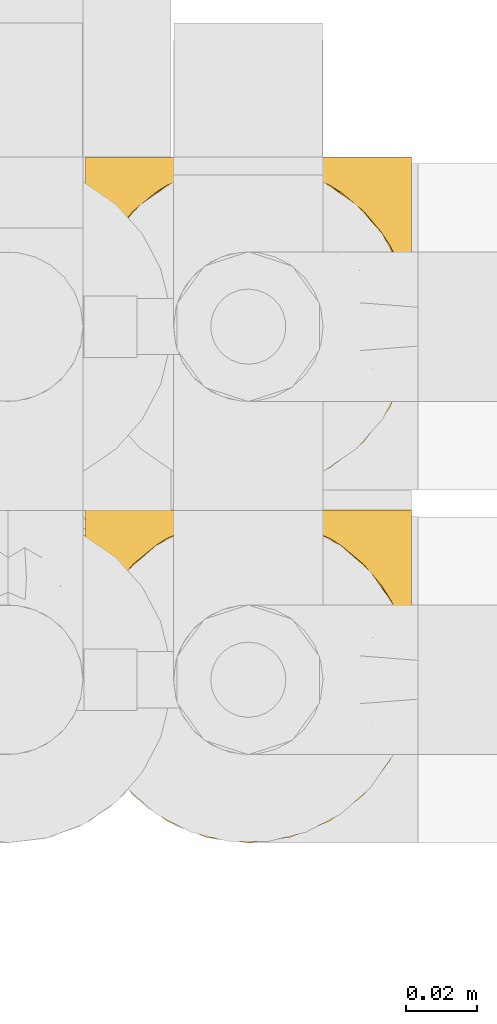
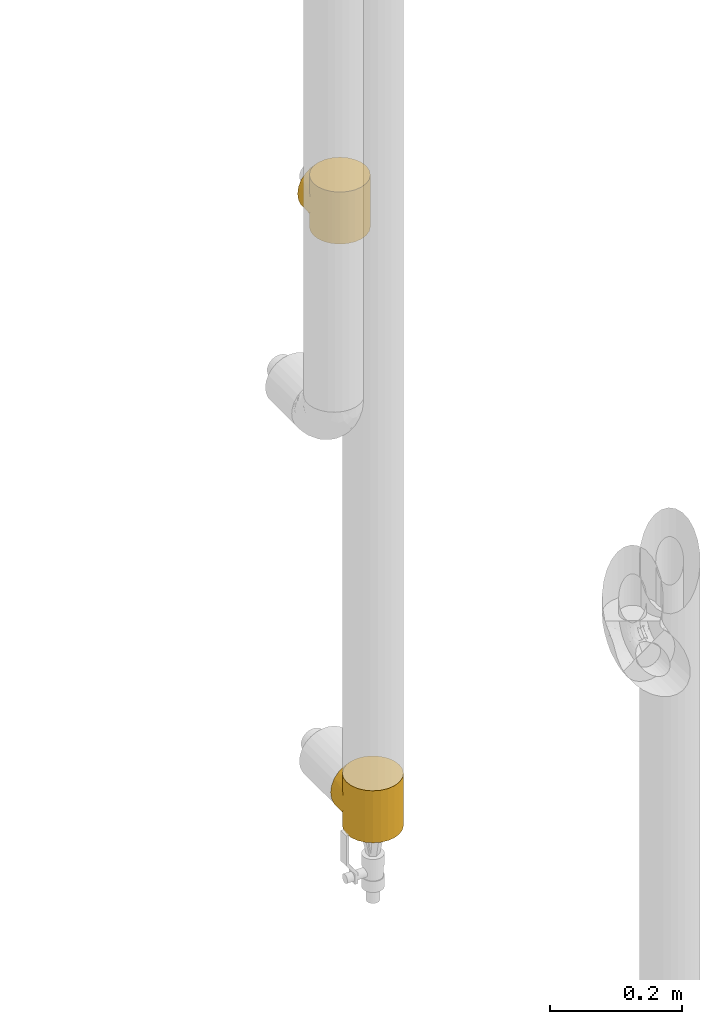
# One storey, part 252 of 827: 2 coverings.
"""IFC2X3 building model written with IfcOpenShell, lengths in millimetres."""

from ifc_helpers import new_model, entity, si_unit, converted_unit, derived_unit, direction, frame, origin, place, context, subcontext, project, spatial, faceted_brep, element, save


model = new_model("IFC2X3")

# Units and contexts
model_context = context("Model", 3, precision=0.01, world=origin(), true_north=direction((6.12303176911189e-17, 1.0)))
body_context = subcontext(model_context, "Body", "Model", "MODEL_VIEW")
ifc_project = project(units=[si_unit("LENGTHUNIT", "METRE", prefix="MILLI"), si_unit("AREAUNIT", "SQUARE_METRE"), si_unit("VOLUMEUNIT", "CUBIC_METRE"), converted_unit("PLANEANGLEUNIT", "DEGREE", entity("IfcRatioMeasure", 0.0174532925199433), si_unit("PLANEANGLEUNIT", "RADIAN"), dimensions=[0, 0, 0, 0, 0, 0, 0]), si_unit("MASSUNIT", "GRAM", prefix="KILO"), derived_unit("MASSDENSITYUNIT", [(si_unit("MASSUNIT", "GRAM", prefix="KILO"), 1), (si_unit("LENGTHUNIT", "METRE"), -3)]), derived_unit("MOMENTOFINERTIAUNIT", [(si_unit("LENGTHUNIT", "METRE"), 4)]), si_unit("TIMEUNIT", "SECOND"), si_unit("FREQUENCYUNIT", "HERTZ"), si_unit("THERMODYNAMICTEMPERATUREUNIT", "DEGREE_CELSIUS"), derived_unit("THERMALTRANSMITTANCEUNIT", [(si_unit("MASSUNIT", "GRAM", prefix="KILO"), 1), (si_unit("THERMODYNAMICTEMPERATUREUNIT", "KELVIN"), -1), (si_unit("TIMEUNIT", "SECOND"), -3)]), derived_unit("VOLUMETRICFLOWRATEUNIT", [(si_unit("LENGTHUNIT", "METRE"), 3), (si_unit("TIMEUNIT", "SECOND"), -1)]), derived_unit("MASSFLOWRATEUNIT", [(si_unit("MASSUNIT", "GRAM", prefix="KILO"), 1), (si_unit("TIMEUNIT", "SECOND"), -1)]), derived_unit("ROTATIONALFREQUENCYUNIT", [(si_unit("TIMEUNIT", "SECOND"), -1)]), si_unit("ELECTRICCURRENTUNIT", "AMPERE"), si_unit("ELECTRICVOLTAGEUNIT", "VOLT"), si_unit("POWERUNIT", "WATT"), si_unit("FORCEUNIT", "NEWTON", prefix="KILO"), si_unit("ILLUMINANCEUNIT", "LUX"), si_unit("LUMINOUSFLUXUNIT", "LUMEN"), si_unit("LUMINOUSINTENSITYUNIT", "CANDELA"), derived_unit("USERDEFINED", [(si_unit("MASSUNIT", "GRAM", prefix="KILO"), -1), (si_unit("LENGTHUNIT", "METRE"), -2), (si_unit("TIMEUNIT", "SECOND"), 3), (si_unit("LUMINOUSFLUXUNIT", "LUMEN"), 1)]), derived_unit("LINEARVELOCITYUNIT", [(si_unit("LENGTHUNIT", "METRE"), 1), (si_unit("TIMEUNIT", "SECOND"), -1)]), si_unit("PRESSUREUNIT", "PASCAL"), derived_unit("USERDEFINED", [(si_unit("LENGTHUNIT", "METRE"), -2), (si_unit("MASSUNIT", "GRAM", prefix="KILO"), 1), (si_unit("TIMEUNIT", "SECOND"), -2)]), derived_unit("LINEARFORCEUNIT", [(si_unit("MASSUNIT", "GRAM", prefix="KILO"), 1), (si_unit("LENGTHUNIT", "METRE"), 1), (si_unit("TIMEUNIT", "SECOND"), -2), (si_unit("LENGTHUNIT", "METRE"), -1)]), derived_unit("PLANARFORCEUNIT", [(si_unit("MASSUNIT", "GRAM", prefix="KILO"), 1), (si_unit("LENGTHUNIT", "METRE"), 1), (si_unit("TIMEUNIT", "SECOND"), -2), (si_unit("LENGTHUNIT", "METRE"), -2)])], contexts=[model_context])

# Site, building, storey
site_placement = place(None, origin())
site = spatial("IfcSite", under=ifc_project, at=site_placement, CompositionType="ELEMENT")
building_placement = place(site_placement, origin())
building = spatial("IfcBuilding", under=site, at=building_placement, CompositionType="ELEMENT")
storey_placement = place(building_placement, frame((0.0, 0.0, 28200.0)))
storey = spatial("IfcBuildingStorey", under=building, at=storey_placement, Name="08", CompositionType="ELEMENT", Elevation=28200.0)

# Coverings
covering_1_placement = place(storey_placement, frame((30583.73, 15793.41, 1404.5)))
element("IfcCovering", 1, at=covering_1_placement, inside=storey, Name=":ADSK_", ObjectType=":ADSK_", PredefinedType="INSULATION", context=body_context, shape_type="Brep", body=[
    faceted_brep([(2.11, 54.7, 54.91), (1.6, 47.8, 96.0), (3.17, 59.75, 96.0), (25.36, 87.94, 88.15), (27.48, 88.96, 96.0), (29.21, 90.09, 90.3), (7.78, 70.9, 96.0), (6.34, 68.19, 68.4), (10.15, 74.57, 74.78), (15.13, 80.46, 96.0), (24.7, 87.81, 96.0), (35.84, 92.42, 96.0), (37.01, 92.61, 92.82), (35.9, 92.25, 92.46), (33.67, 91.53, 91.74), (1.6, 47.8, 48.0), (2.11, 54.7, 41.09), (1.6, 47.8, 0.0), (38.13, 92.97, 93.18), (37.33, 92.62, 96.0), (38.83, 92.81, 96.0), (3.68, 61.53, 61.74), (44.06, 93.5, 96.0), (44.81, 93.6, 96.0), (44.17, 93.61, 93.82), (43.31, 93.4, 96.0), (21.52, 85.79, 86.0), (19.91, 84.13, 96.0), (33.05, 91.27, 96.0), (31.44, 90.81, 91.02), (30.27, 90.11, 96.0), (46.3, 93.8, 96.0), (46.59, 93.87, 94.07), (45.38, 93.74, 93.94), (42.96, 93.48, 93.69), (40.32, 93.01, 96.0), (41.82, 93.21, 96.0), (40.54, 93.23, 93.43), (15.18, 80.52, 80.72), (39.33, 93.1, 93.3), (41.75, 93.36, 93.56), (47.8, 94.0, 96.0), (47.8, 94.0, 94.2), (47.8, 94.0, 0.0), (46.59, 93.87, 1.93), (47.8, 94.0, 1.8), (45.55, 93.7, 96.0), (61.93, 91.53, 91.73), (59.75, 92.42, 96.0), (62.54, 91.27, 96.0), (52.28, 93.4, 96.0), (53.77, 93.21, 96.0), (52.64, 93.48, 93.69), (59.7, 92.25, 92.45), (58.59, 92.61, 92.81), (65.32, 90.11, 96.0), (66.38, 90.09, 90.3), (64.16, 90.81, 91.02), (57.48, 92.97, 93.17), (56.76, 92.81, 96.0), (58.26, 92.62, 96.0), (68.11, 88.96, 96.0), (70.9, 87.81, 96.0), (70.23, 87.94, 88.15), (74.07, 85.8, 86.0), (75.68, 84.13, 96.0), (80.41, 80.52, 80.73), (50.22, 93.74, 93.94), (49.29, 93.8, 96.0), (50.04, 93.7, 96.0), (50.78, 93.6, 96.0), (80.46, 80.46, 96.0), (85.44, 74.58, 74.79), (87.81, 70.9, 96.0), (55.06, 93.23, 93.43), (53.85, 93.35, 93.56), (89.25, 68.2, 68.4), (92.42, 59.75, 96.0), (56.27, 93.1, 93.3), (55.27, 93.01, 96.0), (93.48, 54.7, 54.91), (94.0, 47.8, 96.0), (91.9, 61.54, 61.74), (94.0, 47.8, 48.0), (93.48, 54.7, 41.09), (94.0, 47.8, 0.0), (49.01, 93.87, 94.07), (51.43, 93.61, 93.82), (51.53, 93.5, 96.0), (49.01, 93.87, 1.93), (70.9, 7.78, 0.0), (59.75, 3.17, 0.0), (47.8, 1.6, 0.0), (35.84, 3.17, 0.0), (24.7, 7.78, 0.0), (15.13, 15.13, 0.0), (7.78, 24.7, 0.0), (3.17, 35.84, 0.0), (3.17, 59.75, 0.0), (7.78, 70.9, 0.0), (15.13, 80.46, 0.0), (19.91, 84.13, 0.0), (24.7, 87.81, 0.0), (27.48, 88.96, 0.0), (30.27, 90.11, 0.0), (33.05, 91.27, 0.0), (35.84, 92.42, 0.0), (37.33, 92.62, 0.0), (38.83, 92.81, 0.0), (40.32, 93.01, 0.0), (41.82, 93.21, 0.0), (43.31, 93.4, 0.0), (44.06, 93.5, 0.0), (44.81, 93.6, 0.0), (45.55, 93.7, 0.0), (46.3, 93.8, 0.0), (49.29, 93.8, 0.0), (50.04, 93.7, 0.0), (50.78, 93.6, 0.0), (51.53, 93.5, 0.0), (52.28, 93.4, 0.0), (53.77, 93.21, 0.0), (55.27, 93.01, 0.0), (56.76, 92.81, 0.0), (58.26, 92.62, 0.0), (59.75, 92.42, 0.0), (62.54, 91.27, 0.0), (65.32, 90.11, 0.0), (68.11, 88.96, 0.0), (70.9, 87.81, 0.0), (75.68, 84.13, 0.0), (80.46, 80.46, 0.0), (87.81, 70.9, 0.0), (92.42, 59.75, 0.0), (92.42, 35.84, 0.0), (87.81, 24.7, 0.0), (80.46, 15.13, 0.0), (3.17, 35.84, 96.0), (7.78, 24.7, 96.0), (15.13, 15.13, 96.0), (24.7, 7.78, 96.0), (35.84, 3.17, 96.0), (47.8, 1.6, 96.0), (59.75, 3.17, 96.0), (70.9, 7.78, 96.0), (80.46, 15.13, 96.0), (87.81, 24.7, 96.0), (92.42, 35.84, 96.0), (33.67, 91.53, 4.26), (35.9, 92.25, 3.54), (37.01, 92.61, 3.18), (3.68, 61.53, 34.26), (6.34, 68.19, 27.6), (29.21, 90.09, 5.7), (39.33, 93.1, 2.7), (40.54, 93.23, 2.57), (10.15, 74.57, 21.22), (21.52, 85.79, 10.0), (25.36, 87.94, 7.85), (15.18, 80.52, 15.28), (31.44, 90.81, 4.98), (38.13, 92.97, 2.82), (45.38, 93.74, 2.06), (41.75, 93.36, 2.44), (42.96, 93.48, 2.31), (44.17, 93.61, 2.18), (66.38, 90.09, 5.7), (64.16, 90.81, 4.98), (74.07, 85.8, 10.0), (55.06, 93.23, 2.57), (80.41, 80.52, 15.27), (70.23, 87.94, 7.85), (56.27, 93.1, 2.7), (57.48, 92.97, 2.83), (51.43, 93.61, 2.18), (52.64, 93.48, 2.31), (61.93, 91.53, 4.27), (58.59, 92.61, 3.19), (59.7, 92.25, 3.55), (89.25, 68.2, 27.6), (91.9, 61.54, 34.26), (85.44, 74.58, 21.21), (53.85, 93.35, 2.44), (50.22, 93.74, 2.06), (1.6, 95.8, 48.0), (3.17, 95.8, 59.96), (7.78, 95.8, 71.1), (15.13, 95.8, 80.67), (19.91, 95.8, 84.34), (24.7, 95.8, 88.01), (27.48, 95.8, 89.16), (30.27, 95.8, 90.32), (33.05, 95.8, 91.47), (35.84, 95.8, 92.63), (37.33, 95.8, 92.82), (38.83, 95.8, 93.02), (40.32, 95.8, 93.22), (41.82, 95.8, 93.41), (43.31, 95.8, 93.61), (44.06, 95.8, 93.71), (44.81, 95.8, 93.81), (45.55, 95.8, 93.9), (46.3, 95.8, 94.0), (47.8, 95.8, 94.2), (49.29, 95.8, 94.0), (50.04, 95.8, 93.9), (50.78, 95.8, 93.81), (51.53, 95.8, 93.71), (52.28, 95.8, 93.61), (53.77, 95.8, 93.41), (55.27, 95.8, 93.22), (56.76, 95.8, 93.02), (58.26, 95.8, 92.82), (59.75, 95.8, 92.63), (62.54, 95.8, 91.47), (65.32, 95.8, 90.32), (68.11, 95.8, 89.16), (70.9, 95.8, 88.01), (75.68, 95.8, 84.34), (80.46, 95.8, 80.67), (87.81, 95.8, 71.1), (92.42, 95.8, 59.96), (94.0, 95.8, 48.0), (92.42, 95.8, 36.04), (87.81, 95.8, 24.9), (80.46, 95.8, 15.33), (75.68, 95.8, 11.66), (70.9, 95.8, 7.99), (68.11, 95.8, 6.84), (65.32, 95.8, 5.68), (62.54, 95.8, 4.53), (59.75, 95.8, 3.37), (58.26, 95.8, 3.18), (56.76, 95.8, 2.98), (55.27, 95.8, 2.78), (53.77, 95.8, 2.59), (52.28, 95.8, 2.39), (51.53, 95.8, 2.29), (50.78, 95.8, 2.19), (50.04, 95.8, 2.1), (49.29, 95.8, 2.0), (47.8, 95.8, 1.8), (46.3, 95.8, 2.0), (45.55, 95.8, 2.1), (44.81, 95.8, 2.19), (44.06, 95.8, 2.29), (43.31, 95.8, 2.39), (41.82, 95.8, 2.59), (40.32, 95.8, 2.78), (38.83, 95.8, 2.98), (37.33, 95.8, 3.18), (35.84, 95.8, 3.37), (33.05, 95.8, 4.53), (30.27, 95.8, 5.68), (27.48, 95.8, 6.84), (24.7, 95.8, 7.99), (19.91, 95.8, 11.66), (15.13, 95.8, 15.33), (7.78, 95.8, 24.9), (3.17, 95.8, 36.04)], [[[0, 1, 2]], [[3, 4, 5]], [[2, 6, 7]], [[8, 6, 9]], [[4, 3, 10]], [[8, 7, 6]], [[11, 12, 13, 14]], [[0, 15, 1]], [[15, 16, 17]], [[18, 19, 20]], [[7, 21, 2]], [[0, 2, 21]], [[19, 18, 12]], [[12, 11, 19]], [[22, 23, 24, 25]], [[26, 27, 10]], [[28, 29, 30]], [[28, 11, 14]], [[31, 32, 33]], [[29, 28, 14]], [[34, 25, 24]], [[35, 36, 37]], [[38, 9, 27]], [[38, 27, 26]], [[5, 30, 29]], [[20, 39, 18]], [[5, 4, 30]], [[26, 10, 3]], [[35, 39, 20]], [[9, 38, 8]], [[36, 34, 40, 37]], [[34, 36, 25]], [[39, 35, 37]], [[32, 41, 42]], [[43, 44, 45]], [[23, 33, 24]], [[33, 23, 46, 31]], [[41, 32, 31]], [[47, 48, 49]], [[50, 51, 52]], [[48, 47, 53, 54]], [[55, 56, 57]], [[58, 59, 60]], [[61, 62, 63]], [[49, 57, 47]], [[58, 60, 54]], [[64, 62, 65]], [[66, 64, 65]], [[61, 63, 56]], [[67, 68, 69, 70]], [[65, 71, 66]], [[62, 64, 63]], [[72, 71, 73]], [[51, 74, 75, 52]], [[76, 73, 77]], [[78, 79, 59]], [[59, 58, 78]], [[80, 77, 81]], [[79, 78, 74]], [[76, 72, 73]], [[80, 82, 77]], [[83, 80, 81]], [[84, 83, 85]], [[56, 55, 61]], [[76, 77, 82]], [[57, 49, 55]], [[48, 54, 60]], [[71, 72, 66]], [[74, 51, 79]], [[86, 41, 68]], [[87, 50, 52]], [[70, 87, 67]], [[50, 87, 70, 88]], [[41, 86, 42]], [[89, 43, 45]], [[68, 67, 86]], [[90, 91, 92, 93, 94, 95, 96, 97, 17, 98, 99, 100, 101, 102, 103, 104, 105, 106, 107, 108, 109, 110, 111, 112, 113, 114, 115, 43, 116, 117, 118, 119, 120, 121, 122, 123, 124, 125, 126, 127, 128, 129, 130, 131, 132, 133, 85, 134, 135, 136]], [[1, 137, 138, 139, 140, 141, 142, 143, 144, 145, 146, 147, 81, 77, 73, 71, 65, 62, 61, 55, 49, 48, 60, 59, 79, 51, 50, 88, 70, 69, 68, 41, 31, 46, 23, 22, 25, 36, 35, 20, 19, 11, 28, 30, 4, 10, 27, 9, 6, 2]], [[140, 139, 95, 94]], [[92, 142, 141, 93]], [[141, 140, 94, 93]], [[96, 138, 137, 97]], [[1, 15, 17, 97, 137]], [[95, 139, 138, 96]], [[106, 148, 149, 150]], [[151, 152, 98]], [[153, 104, 103]], [[148, 106, 105]], [[16, 151, 98]], [[109, 154, 155]], [[17, 16, 98]], [[99, 156, 100]], [[99, 98, 152]], [[156, 99, 152]], [[102, 157, 158]], [[106, 150, 107]], [[155, 110, 109]], [[157, 101, 159]], [[105, 160, 148]], [[161, 107, 150]], [[162, 115, 114, 113]], [[157, 102, 101]], [[153, 103, 158]], [[104, 153, 160]], [[159, 101, 100]], [[102, 158, 103]], [[108, 161, 154]], [[110, 155, 163, 164]], [[164, 111, 110]], [[161, 108, 107]], [[160, 105, 104]], [[159, 100, 156]], [[154, 109, 108]], [[44, 43, 115]], [[165, 111, 164]], [[113, 165, 162]], [[111, 165, 113, 112]], [[115, 162, 44]], [[166, 127, 167]], [[166, 128, 127]], [[129, 168, 130]], [[122, 121, 169]], [[170, 130, 168]], [[171, 168, 129]], [[123, 172, 173]], [[119, 118, 174, 120]], [[128, 171, 129]], [[174, 175, 120]], [[126, 125, 176]], [[171, 128, 166]], [[170, 131, 130]], [[125, 177, 178, 176]], [[179, 180, 133]], [[173, 124, 123]], [[177, 125, 124]], [[180, 84, 133]], [[131, 181, 132]], [[181, 131, 170]], [[179, 132, 181]], [[179, 133, 132]], [[121, 175, 182, 169]], [[167, 126, 176]], [[84, 85, 133]], [[126, 167, 127]], [[122, 172, 123]], [[124, 173, 177]], [[116, 89, 183]], [[175, 121, 120]], [[172, 122, 169]], [[118, 183, 174]], [[183, 118, 117, 116]], [[43, 89, 116]], [[83, 81, 147, 134, 85]], [[134, 147, 146, 135]], [[146, 145, 136, 135]], [[136, 145, 144, 90]], [[90, 144, 143, 91]], [[91, 143, 142, 92]], [[184, 185, 186, 187, 188, 189, 190, 191, 192, 193, 194, 195, 196, 197, 198, 199, 200, 201, 202, 203, 204, 205, 206, 207, 208, 209, 210, 211, 212, 213, 214, 215, 216, 217, 218, 219, 220, 221, 222, 223, 224, 225, 226, 227, 228, 229, 230, 231, 232, 233, 234, 235, 236, 237, 238, 239, 240, 241, 242, 243, 244, 245, 246, 247, 248, 249, 250, 251, 252, 253, 254, 255, 256, 257, 258, 259]], [[39, 196, 195]], [[198, 197, 34]], [[193, 14, 13, 12]], [[5, 191, 190]], [[14, 193, 192]], [[190, 189, 3]], [[192, 29, 14]], [[18, 194, 12]], [[26, 189, 188]], [[38, 26, 188]], [[190, 3, 5]], [[33, 202, 201, 200]], [[188, 187, 38]], [[189, 26, 3]], [[8, 187, 186]], [[29, 192, 191]], [[7, 186, 185]], [[193, 12, 194]], [[0, 185, 184]], [[191, 5, 29]], [[7, 8, 186]], [[197, 37, 40, 34]], [[0, 21, 185]], [[15, 0, 184]], [[18, 195, 194]], [[7, 185, 21]], [[196, 39, 37]], [[187, 8, 38]], [[37, 197, 196]], [[195, 18, 39]], [[32, 203, 202]], [[24, 198, 34]], [[200, 24, 33]], [[198, 24, 200, 199]], [[203, 32, 42]], [[202, 33, 32]], [[16, 184, 259]], [[158, 254, 153]], [[259, 258, 152]], [[156, 258, 257]], [[254, 158, 255]], [[156, 152, 258]], [[251, 150, 149, 148]], [[16, 15, 184]], [[161, 250, 249]], [[152, 151, 259]], [[16, 259, 151]], [[250, 161, 150]], [[150, 251, 250]], [[245, 244, 165, 246]], [[157, 256, 255]], [[252, 160, 253]], [[252, 251, 148]], [[242, 44, 162]], [[160, 252, 148]], [[164, 246, 165]], [[248, 247, 155]], [[159, 257, 256]], [[159, 256, 157]], [[153, 253, 160]], [[249, 154, 161]], [[153, 254, 253]], [[157, 255, 158]], [[248, 154, 249]], [[257, 159, 156]], [[247, 164, 163, 155]], [[164, 247, 246]], [[154, 248, 155]], [[44, 241, 45]], [[244, 162, 165]], [[162, 244, 243, 242]], [[241, 44, 242]], [[176, 231, 230]], [[236, 235, 175]], [[231, 176, 178, 177]], [[229, 166, 167]], [[173, 233, 232]], [[228, 227, 171]], [[230, 167, 176]], [[173, 232, 177]], [[168, 227, 226]], [[170, 168, 226]], [[228, 171, 166]], [[183, 240, 239, 238]], [[226, 225, 170]], [[227, 168, 171]], [[181, 225, 224]], [[235, 169, 182, 175]], [[179, 224, 223]], [[172, 234, 233]], [[233, 173, 172]], [[84, 223, 222]], [[234, 172, 169]], [[179, 181, 224]], [[84, 180, 223]], [[83, 84, 222]], [[166, 229, 228]], [[179, 223, 180]], [[167, 230, 229]], [[231, 177, 232]], [[225, 181, 170]], [[169, 235, 234]], [[89, 241, 240]], [[174, 236, 175]], [[238, 174, 183]], [[236, 174, 238, 237]], [[241, 89, 45]], [[240, 183, 89]], [[80, 222, 221]], [[209, 52, 75, 74]], [[221, 220, 76]], [[72, 220, 219]], [[210, 78, 211]], [[72, 76, 220]], [[63, 216, 56]], [[80, 83, 222]], [[54, 213, 212]], [[76, 82, 221]], [[80, 221, 82]], [[58, 212, 211]], [[216, 63, 217]], [[207, 206, 87, 208]], [[64, 218, 217]], [[204, 86, 67]], [[214, 213, 47]], [[57, 214, 47]], [[212, 58, 54]], [[52, 208, 87]], [[210, 209, 74]], [[66, 219, 218]], [[66, 218, 64]], [[56, 215, 57]], [[211, 78, 58]], [[56, 216, 215]], [[64, 217, 63]], [[213, 54, 53, 47]], [[219, 66, 72]], [[214, 57, 215]], [[52, 209, 208]], [[78, 210, 74]], [[86, 203, 42]], [[206, 67, 87]], [[67, 206, 205, 204]], [[203, 86, 204]]]),
])
covering_2_placement = place(storey_placement, frame((30583.73, 15693.41, 359.5)))
element("IfcCovering", 2, at=covering_2_placement, inside=storey, Name=":ADSK_", ObjectType=":ADSK_", PredefinedType="INSULATION", context=body_context, shape_type="Brep", body=[
    faceted_brep([(2.11, 54.7, 54.91), (1.6, 47.8, 96.0), (3.17, 59.75, 96.0), (25.36, 87.94, 88.15), (27.48, 88.96, 96.0), (29.21, 90.09, 90.3), (7.78, 70.9, 96.0), (6.34, 68.19, 68.4), (10.15, 74.57, 74.78), (15.13, 80.46, 96.0), (24.7, 87.81, 96.0), (35.84, 92.42, 96.0), (37.01, 92.61, 92.82), (35.9, 92.25, 92.46), (33.67, 91.53, 91.74), (1.6, 47.8, 48.0), (2.11, 54.7, 41.09), (1.6, 47.8, 0.0), (38.13, 92.97, 93.18), (37.33, 92.62, 96.0), (38.83, 92.81, 96.0), (3.68, 61.53, 61.74), (44.06, 93.5, 96.0), (44.81, 93.6, 96.0), (44.17, 93.61, 93.82), (43.31, 93.4, 96.0), (21.52, 85.79, 86.0), (19.91, 84.13, 96.0), (33.05, 91.27, 96.0), (31.44, 90.81, 91.02), (30.27, 90.11, 96.0), (46.3, 93.8, 96.0), (46.59, 93.87, 94.07), (45.38, 93.74, 93.94), (42.96, 93.48, 93.69), (40.32, 93.01, 96.0), (41.82, 93.21, 96.0), (40.54, 93.23, 93.43), (15.18, 80.52, 80.72), (39.33, 93.1, 93.3), (41.75, 93.36, 93.56), (47.8, 94.0, 96.0), (47.8, 94.0, 94.2), (47.8, 94.0, 0.0), (46.59, 93.87, 1.93), (47.8, 94.0, 1.8), (45.55, 93.7, 96.0), (61.93, 91.53, 91.73), (59.75, 92.42, 96.0), (62.54, 91.27, 96.0), (52.28, 93.4, 96.0), (53.77, 93.21, 96.0), (52.64, 93.48, 93.69), (59.7, 92.25, 92.45), (58.59, 92.61, 92.81), (65.32, 90.11, 96.0), (66.38, 90.09, 90.3), (64.16, 90.81, 91.02), (57.48, 92.97, 93.17), (56.76, 92.81, 96.0), (58.26, 92.62, 96.0), (68.11, 88.96, 96.0), (70.9, 87.81, 96.0), (70.23, 87.94, 88.15), (74.07, 85.8, 86.0), (75.68, 84.13, 96.0), (80.41, 80.52, 80.73), (50.22, 93.74, 93.94), (49.29, 93.8, 96.0), (50.04, 93.7, 96.0), (50.78, 93.6, 96.0), (80.46, 80.46, 96.0), (85.44, 74.58, 74.79), (87.81, 70.9, 96.0), (55.06, 93.23, 93.43), (53.85, 93.35, 93.56), (89.25, 68.2, 68.4), (92.42, 59.75, 96.0), (56.27, 93.1, 93.3), (55.27, 93.01, 96.0), (93.48, 54.7, 54.91), (94.0, 47.8, 96.0), (91.9, 61.54, 61.74), (94.0, 47.8, 48.0), (93.48, 54.7, 41.09), (94.0, 47.8, 0.0), (49.01, 93.87, 94.07), (51.43, 93.61, 93.82), (51.53, 93.5, 96.0), (49.01, 93.87, 1.93), (70.9, 7.78, 0.0), (59.75, 3.17, 0.0), (47.8, 1.6, 0.0), (35.84, 3.17, 0.0), (24.7, 7.78, 0.0), (15.13, 15.13, 0.0), (7.78, 24.7, 0.0), (3.17, 35.84, 0.0), (3.17, 59.75, 0.0), (7.78, 70.9, 0.0), (15.13, 80.46, 0.0), (19.91, 84.13, 0.0), (24.7, 87.81, 0.0), (27.48, 88.96, 0.0), (30.27, 90.11, 0.0), (33.05, 91.27, 0.0), (35.84, 92.42, 0.0), (37.33, 92.62, 0.0), (38.83, 92.81, 0.0), (40.32, 93.01, 0.0), (41.82, 93.21, 0.0), (43.31, 93.4, 0.0), (44.06, 93.5, 0.0), (44.81, 93.6, 0.0), (45.55, 93.7, 0.0), (46.3, 93.8, 0.0), (49.29, 93.8, 0.0), (50.04, 93.7, 0.0), (50.78, 93.6, 0.0), (51.53, 93.5, 0.0), (52.28, 93.4, 0.0), (53.77, 93.21, 0.0), (55.27, 93.01, 0.0), (56.76, 92.81, 0.0), (58.26, 92.62, 0.0), (59.75, 92.42, 0.0), (62.54, 91.27, 0.0), (65.32, 90.11, 0.0), (68.11, 88.96, 0.0), (70.9, 87.81, 0.0), (75.68, 84.13, 0.0), (80.46, 80.46, 0.0), (87.81, 70.9, 0.0), (92.42, 59.75, 0.0), (92.42, 35.84, 0.0), (87.81, 24.7, 0.0), (80.46, 15.13, 0.0), (3.17, 35.84, 96.0), (7.78, 24.7, 96.0), (15.13, 15.13, 96.0), (24.7, 7.78, 96.0), (35.84, 3.17, 96.0), (47.8, 1.6, 96.0), (59.75, 3.17, 96.0), (70.9, 7.78, 96.0), (80.46, 15.13, 96.0), (87.81, 24.7, 96.0), (92.42, 35.84, 96.0), (33.67, 91.53, 4.26), (35.9, 92.25, 3.54), (37.01, 92.61, 3.18), (3.68, 61.53, 34.26), (6.34, 68.19, 27.6), (29.21, 90.09, 5.7), (39.33, 93.1, 2.7), (40.54, 93.23, 2.57), (10.15, 74.57, 21.22), (21.52, 85.79, 10.0), (25.36, 87.94, 7.85), (15.18, 80.52, 15.28), (31.44, 90.81, 4.98), (38.13, 92.97, 2.82), (45.38, 93.74, 2.06), (41.75, 93.36, 2.44), (42.96, 93.48, 2.31), (44.17, 93.61, 2.18), (66.38, 90.09, 5.7), (64.16, 90.81, 4.98), (74.07, 85.8, 10.0), (55.06, 93.23, 2.57), (80.41, 80.52, 15.27), (70.23, 87.94, 7.85), (56.27, 93.1, 2.7), (57.48, 92.97, 2.83), (51.43, 93.61, 2.18), (52.64, 93.48, 2.31), (61.93, 91.53, 4.27), (58.59, 92.61, 3.19), (59.7, 92.25, 3.55), (89.25, 68.2, 27.6), (91.9, 61.54, 34.26), (85.44, 74.58, 21.21), (53.85, 93.35, 2.44), (50.22, 93.74, 2.06), (1.6, 95.8, 48.0), (3.17, 95.8, 59.96), (7.78, 95.8, 71.1), (15.13, 95.8, 80.67), (19.91, 95.8, 84.34), (24.7, 95.8, 88.01), (27.48, 95.8, 89.16), (30.27, 95.8, 90.32), (33.05, 95.8, 91.47), (35.84, 95.8, 92.63), (37.33, 95.8, 92.82), (38.83, 95.8, 93.02), (40.32, 95.8, 93.22), (41.82, 95.8, 93.41), (43.31, 95.8, 93.61), (44.06, 95.8, 93.71), (44.81, 95.8, 93.81), (45.55, 95.8, 93.9), (46.3, 95.8, 94.0), (47.8, 95.8, 94.2), (49.29, 95.8, 94.0), (50.04, 95.8, 93.9), (50.78, 95.8, 93.81), (51.53, 95.8, 93.71), (52.28, 95.8, 93.61), (53.77, 95.8, 93.41), (55.27, 95.8, 93.22), (56.76, 95.8, 93.02), (58.26, 95.8, 92.82), (59.75, 95.8, 92.63), (62.54, 95.8, 91.47), (65.32, 95.8, 90.32), (68.11, 95.8, 89.16), (70.9, 95.8, 88.01), (75.68, 95.8, 84.34), (80.46, 95.8, 80.67), (87.81, 95.8, 71.1), (92.42, 95.8, 59.96), (94.0, 95.8, 48.0), (92.42, 95.8, 36.04), (87.81, 95.8, 24.9), (80.46, 95.8, 15.33), (75.68, 95.8, 11.66), (70.9, 95.8, 7.99), (68.11, 95.8, 6.84), (65.32, 95.8, 5.68), (62.54, 95.8, 4.53), (59.75, 95.8, 3.37), (58.26, 95.8, 3.18), (56.76, 95.8, 2.98), (55.27, 95.8, 2.78), (53.77, 95.8, 2.59), (52.28, 95.8, 2.39), (51.53, 95.8, 2.29), (50.78, 95.8, 2.19), (50.04, 95.8, 2.1), (49.29, 95.8, 2.0), (47.8, 95.8, 1.8), (46.3, 95.8, 2.0), (45.55, 95.8, 2.1), (44.81, 95.8, 2.19), (44.06, 95.8, 2.29), (43.31, 95.8, 2.39), (41.82, 95.8, 2.59), (40.32, 95.8, 2.78), (38.83, 95.8, 2.98), (37.33, 95.8, 3.18), (35.84, 95.8, 3.37), (33.05, 95.8, 4.53), (30.27, 95.8, 5.68), (27.48, 95.8, 6.84), (24.7, 95.8, 7.99), (19.91, 95.8, 11.66), (15.13, 95.8, 15.33), (7.78, 95.8, 24.9), (3.17, 95.8, 36.04)], [[[0, 1, 2]], [[3, 4, 5]], [[2, 6, 7]], [[8, 6, 9]], [[4, 3, 10]], [[8, 7, 6]], [[11, 12, 13, 14]], [[0, 15, 1]], [[15, 16, 17]], [[18, 19, 20]], [[7, 21, 2]], [[0, 2, 21]], [[19, 18, 12]], [[12, 11, 19]], [[22, 23, 24, 25]], [[26, 27, 10]], [[28, 29, 30]], [[28, 11, 14]], [[31, 32, 33]], [[29, 28, 14]], [[34, 25, 24]], [[35, 36, 37]], [[38, 9, 27]], [[38, 27, 26]], [[5, 30, 29]], [[20, 39, 18]], [[5, 4, 30]], [[26, 10, 3]], [[35, 39, 20]], [[9, 38, 8]], [[36, 34, 40, 37]], [[34, 36, 25]], [[39, 35, 37]], [[32, 41, 42]], [[43, 44, 45]], [[23, 33, 24]], [[33, 23, 46, 31]], [[41, 32, 31]], [[47, 48, 49]], [[50, 51, 52]], [[48, 47, 53, 54]], [[55, 56, 57]], [[58, 59, 60]], [[61, 62, 63]], [[49, 57, 47]], [[58, 60, 54]], [[64, 62, 65]], [[66, 64, 65]], [[61, 63, 56]], [[67, 68, 69, 70]], [[65, 71, 66]], [[62, 64, 63]], [[72, 71, 73]], [[51, 74, 75, 52]], [[76, 73, 77]], [[78, 79, 59]], [[59, 58, 78]], [[80, 77, 81]], [[79, 78, 74]], [[76, 72, 73]], [[80, 82, 77]], [[83, 80, 81]], [[84, 83, 85]], [[56, 55, 61]], [[76, 77, 82]], [[57, 49, 55]], [[48, 54, 60]], [[71, 72, 66]], [[74, 51, 79]], [[86, 41, 68]], [[87, 50, 52]], [[70, 87, 67]], [[50, 87, 70, 88]], [[41, 86, 42]], [[89, 43, 45]], [[68, 67, 86]], [[90, 91, 92, 93, 94, 95, 96, 97, 17, 98, 99, 100, 101, 102, 103, 104, 105, 106, 107, 108, 109, 110, 111, 112, 113, 114, 115, 43, 116, 117, 118, 119, 120, 121, 122, 123, 124, 125, 126, 127, 128, 129, 130, 131, 132, 133, 85, 134, 135, 136]], [[1, 137, 138, 139, 140, 141, 142, 143, 144, 145, 146, 147, 81, 77, 73, 71, 65, 62, 61, 55, 49, 48, 60, 59, 79, 51, 50, 88, 70, 69, 68, 41, 31, 46, 23, 22, 25, 36, 35, 20, 19, 11, 28, 30, 4, 10, 27, 9, 6, 2]], [[140, 139, 95, 94]], [[92, 142, 141, 93]], [[141, 140, 94, 93]], [[96, 138, 137, 97]], [[1, 15, 17, 97, 137]], [[95, 139, 138, 96]], [[106, 148, 149, 150]], [[151, 152, 98]], [[153, 104, 103]], [[148, 106, 105]], [[16, 151, 98]], [[109, 154, 155]], [[17, 16, 98]], [[99, 156, 100]], [[99, 98, 152]], [[156, 99, 152]], [[102, 157, 158]], [[106, 150, 107]], [[155, 110, 109]], [[157, 101, 159]], [[105, 160, 148]], [[161, 107, 150]], [[162, 115, 114, 113]], [[157, 102, 101]], [[153, 103, 158]], [[104, 153, 160]], [[159, 101, 100]], [[102, 158, 103]], [[108, 161, 154]], [[110, 155, 163, 164]], [[164, 111, 110]], [[161, 108, 107]], [[160, 105, 104]], [[159, 100, 156]], [[154, 109, 108]], [[44, 43, 115]], [[165, 111, 164]], [[113, 165, 162]], [[111, 165, 113, 112]], [[115, 162, 44]], [[166, 127, 167]], [[166, 128, 127]], [[129, 168, 130]], [[122, 121, 169]], [[170, 130, 168]], [[171, 168, 129]], [[123, 172, 173]], [[119, 118, 174, 120]], [[128, 171, 129]], [[174, 175, 120]], [[126, 125, 176]], [[171, 128, 166]], [[170, 131, 130]], [[125, 177, 178, 176]], [[179, 180, 133]], [[173, 124, 123]], [[177, 125, 124]], [[180, 84, 133]], [[131, 181, 132]], [[181, 131, 170]], [[179, 132, 181]], [[179, 133, 132]], [[121, 175, 182, 169]], [[167, 126, 176]], [[84, 85, 133]], [[126, 167, 127]], [[122, 172, 123]], [[124, 173, 177]], [[116, 89, 183]], [[175, 121, 120]], [[172, 122, 169]], [[118, 183, 174]], [[183, 118, 117, 116]], [[43, 89, 116]], [[83, 81, 147, 134, 85]], [[134, 147, 146, 135]], [[146, 145, 136, 135]], [[136, 145, 144, 90]], [[90, 144, 143, 91]], [[91, 143, 142, 92]], [[184, 185, 186, 187, 188, 189, 190, 191, 192, 193, 194, 195, 196, 197, 198, 199, 200, 201, 202, 203, 204, 205, 206, 207, 208, 209, 210, 211, 212, 213, 214, 215, 216, 217, 218, 219, 220, 221, 222, 223, 224, 225, 226, 227, 228, 229, 230, 231, 232, 233, 234, 235, 236, 237, 238, 239, 240, 241, 242, 243, 244, 245, 246, 247, 248, 249, 250, 251, 252, 253, 254, 255, 256, 257, 258, 259]], [[39, 196, 195]], [[198, 197, 34]], [[193, 14, 13, 12]], [[5, 191, 190]], [[14, 193, 192]], [[190, 189, 3]], [[192, 29, 14]], [[18, 194, 12]], [[26, 189, 188]], [[38, 26, 188]], [[190, 3, 5]], [[33, 202, 201, 200]], [[188, 187, 38]], [[189, 26, 3]], [[8, 187, 186]], [[29, 192, 191]], [[7, 186, 185]], [[193, 12, 194]], [[0, 185, 184]], [[191, 5, 29]], [[7, 8, 186]], [[197, 37, 40, 34]], [[0, 21, 185]], [[15, 0, 184]], [[18, 195, 194]], [[7, 185, 21]], [[196, 39, 37]], [[187, 8, 38]], [[37, 197, 196]], [[195, 18, 39]], [[32, 203, 202]], [[24, 198, 34]], [[200, 24, 33]], [[198, 24, 200, 199]], [[203, 32, 42]], [[202, 33, 32]], [[16, 184, 259]], [[158, 254, 153]], [[259, 258, 152]], [[156, 258, 257]], [[254, 158, 255]], [[156, 152, 258]], [[251, 150, 149, 148]], [[16, 15, 184]], [[161, 250, 249]], [[152, 151, 259]], [[16, 259, 151]], [[250, 161, 150]], [[150, 251, 250]], [[245, 244, 165, 246]], [[157, 256, 255]], [[252, 160, 253]], [[252, 251, 148]], [[242, 44, 162]], [[160, 252, 148]], [[164, 246, 165]], [[248, 247, 155]], [[159, 257, 256]], [[159, 256, 157]], [[153, 253, 160]], [[249, 154, 161]], [[153, 254, 253]], [[157, 255, 158]], [[248, 154, 249]], [[257, 159, 156]], [[247, 164, 163, 155]], [[164, 247, 246]], [[154, 248, 155]], [[44, 241, 45]], [[244, 162, 165]], [[162, 244, 243, 242]], [[241, 44, 242]], [[176, 231, 230]], [[236, 235, 175]], [[231, 176, 178, 177]], [[229, 166, 167]], [[173, 233, 232]], [[228, 227, 171]], [[230, 167, 176]], [[173, 232, 177]], [[168, 227, 226]], [[170, 168, 226]], [[228, 171, 166]], [[183, 240, 239, 238]], [[226, 225, 170]], [[227, 168, 171]], [[181, 225, 224]], [[235, 169, 182, 175]], [[179, 224, 223]], [[172, 234, 233]], [[233, 173, 172]], [[84, 223, 222]], [[234, 172, 169]], [[179, 181, 224]], [[84, 180, 223]], [[83, 84, 222]], [[166, 229, 228]], [[179, 223, 180]], [[167, 230, 229]], [[231, 177, 232]], [[225, 181, 170]], [[169, 235, 234]], [[89, 241, 240]], [[174, 236, 175]], [[238, 174, 183]], [[236, 174, 238, 237]], [[241, 89, 45]], [[240, 183, 89]], [[80, 222, 221]], [[209, 52, 75, 74]], [[221, 220, 76]], [[72, 220, 219]], [[210, 78, 211]], [[72, 76, 220]], [[63, 216, 56]], [[80, 83, 222]], [[54, 213, 212]], [[76, 82, 221]], [[80, 221, 82]], [[58, 212, 211]], [[216, 63, 217]], [[207, 206, 87, 208]], [[64, 218, 217]], [[204, 86, 67]], [[214, 213, 47]], [[57, 214, 47]], [[212, 58, 54]], [[52, 208, 87]], [[210, 209, 74]], [[66, 219, 218]], [[66, 218, 64]], [[56, 215, 57]], [[211, 78, 58]], [[56, 216, 215]], [[64, 217, 63]], [[213, 54, 53, 47]], [[219, 66, 72]], [[214, 57, 215]], [[52, 209, 208]], [[78, 210, 74]], [[86, 203, 42]], [[206, 67, 87]], [[67, 206, 205, 204]], [[203, 86, 204]]]),
])

save(model, "model.ifc")
